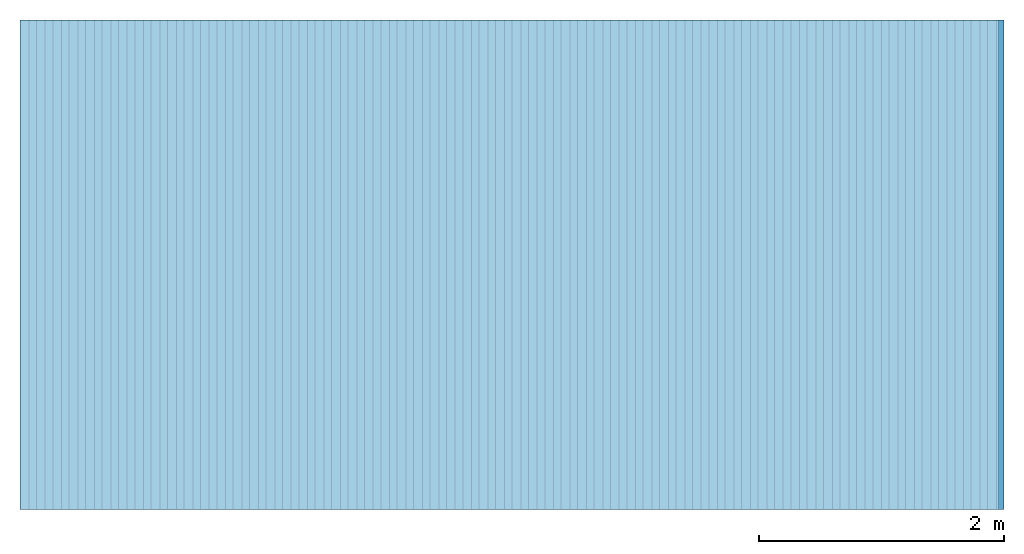
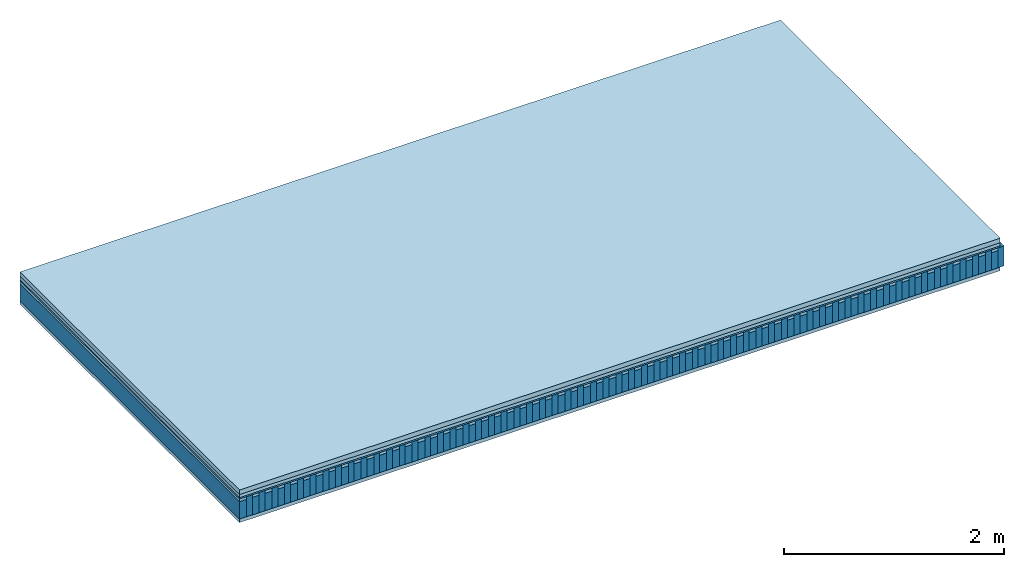
# One storey: 5 plates, 2 members, 1 element without a shape of its own.
"""IFC4 building model written with IfcOpenShell, lengths in metres."""

import ifcopenshell
import ifcopenshell.guid

model = None  # the IFC model being written
_history = None  # IfcOwnerHistory: only IFC2X3 demands one
_inside = {}  # id of a spatial element -> (the spatial element, [elements in it])
_under = {}  # id of a project, library or spatial element -> (it, [spatial elements below it])
_declared = {}  # id of a project -> (the project, [libraries it declares])
_typed = {}  # id of a type object -> (the type object, [elements of that type])
_made_of = {}  # id of a material, layer set ... -> (it, [elements and type objects made of it])


def new_model(schema):
    """Start an empty IFC model of exactly this schema.

    Asked for "IFC4X3", IfcOpenShell would pick the latest addendum, in which some entities
    have other attributes; the version numbers below select the first issue.
    IFC2X3 requires an IfcOwnerHistory on every rooted entity: one is made here for all.
    """
    global model, _history
    if schema == "IFC4X3":
        model = ifcopenshell.file(schema_version=(4, 3, 0, 0))
    else:
        model = ifcopenshell.file(schema=schema)
    _inside.clear()
    _under.clear()
    _declared.clear()
    _typed.clear()
    _made_of.clear()
    _history = None
    if model.schema == "IFC2X3":
        org = make("IfcOrganization", Name="unknown")
        user = make(
            "IfcPersonAndOrganization",
            ThePerson=make("IfcPerson", FamilyName="unknown"),
            TheOrganization=org,
        )
        app = make(
            "IfcApplication",
            ApplicationDeveloper=org,
            Version="unknown",
            ApplicationFullName="unknown",
            ApplicationIdentifier="unknown",
        )
        _history = make(
            "IfcOwnerHistory",
            OwningUser=user,
            OwningApplication=app,
            ChangeAction="ADDED",
            CreationDate=0,
        )
    return model


def make(cls, **values):
    """One entity of the class cls with the attributes given. An attribute that is None is left unset."""
    return model.create_entity(
        cls, **{name: value for name, value in values.items() if value is not None}
    )


def rooted(cls, **values):
    """An entity with a GlobalId (a new one), such as an element, a storey or a relation."""
    return make(cls, GlobalId=ifcopenshell.guid.new(), OwnerHistory=_history, **values)


def si_unit(unit_type, name, prefix=None):
    """IfcSIUnit, for example si_unit("LENGTHUNIT", "METRE", prefix="MILLI")."""
    return make("IfcSIUnit", UnitType=unit_type, Prefix=prefix, Name=name)


def derived_unit(unit_type, elements):
    """IfcDerivedUnit: a product of units, each with its exponent."""
    return make(
        "IfcDerivedUnit",
        Elements=[
            make("IfcDerivedUnitElement", Unit=unit, Exponent=power)
            for unit, power in elements
        ],
        UnitType=unit_type,
    )


def assignment(units):
    """IfcUnitAssignment: the units of a project."""
    return None if units is None else make("IfcUnitAssignment", Units=units)


def point(xyz):
    """IfcCartesianPoint."""
    return None if xyz is None else make("IfcCartesianPoint", Coordinates=xyz)


def direction(xyz):
    """IfcDirection."""
    return None if xyz is None else make("IfcDirection", DirectionRatios=xyz)


def frame(location, z_axis=None, x_axis=None):
    """IfcAxis2Placement3D, a coordinate frame: its origin and axes. An axis left out is left unset."""
    return make(
        "IfcAxis2Placement3D",
        Location=point(location),
        Axis=direction(z_axis),
        RefDirection=direction(x_axis),
    )


def frame_2d(location, x_axis=None):
    """IfcAxis2Placement2D, a coordinate frame in the plane: its origin and x axis."""
    return make(
        "IfcAxis2Placement2D", Location=point(location), RefDirection=direction(x_axis)
    )


def origin():
    """The frame at (0, 0, 0) with its axes left unset."""
    return frame((0.0, 0.0, 0.0))


def origin_with_axes():
    """The frame at (0, 0, 0) with the z axis (0, 0, 1) and the x axis (1, 0, 0) written out."""
    return frame((0.0, 0.0, 0.0), z_axis=(0.0, 0.0, 1.0), x_axis=(1.0, 0.0, 0.0))


def place(relative_to, where):
    """IfcLocalPlacement: puts the frame where relative to a parent placement (None: the world)."""
    return make(
        "IfcLocalPlacement", PlacementRelTo=relative_to, RelativePlacement=where
    )


def context(
    kind, dimensions, precision=None, world=None, true_north=None, identifier=None
):
    """IfcGeometricRepresentationContext, for example the 3D "Model" context."""
    return make(
        "IfcGeometricRepresentationContext",
        ContextIdentifier=identifier,
        ContextType=kind,
        CoordinateSpaceDimension=dimensions,
        Precision=precision,
        WorldCoordinateSystem=world,
        TrueNorth=true_north,
    )


def project(units=None, contexts=None):
    """IfcProject with its units and contexts."""
    return rooted(
        "IfcProject",
        Name="project",
        RepresentationContexts=contexts,
        UnitsInContext=assignment(units),
    )


def spatial(cls, under=None, at=None, **own):
    """A site, building, storey or space (cls), placed at a placement, below another one or the project."""
    s = rooted(cls, ObjectPlacement=at, **own)
    if under is not None:
        _under.setdefault(under.id(), (under, []))[1].append(s)
    return s


def profile(cls, at=None, kind="AREA", **sizes):
    """A parametric profile (cls). Its sizes go by their IFC names, for example OverallWidth=200.0."""
    return make(cls, ProfileType=kind, Position=at, **sizes)


def rectangle(**sizes):
    """IfcRectangleProfileDef."""
    return profile("IfcRectangleProfileDef", **sizes)


def extrude(swept, where, along, depth):
    """IfcExtrudedAreaSolid: the profile swept, set in the frame where, extruded along a direction by depth."""
    return make(
        "IfcExtrudedAreaSolid",
        SweptArea=swept,
        Position=where,
        ExtrudedDirection=direction(along),
        Depth=depth,
    )


def shape(context_of_items, identifier, shape_type, items):
    """IfcShapeRepresentation: the items that make up one representation, for example the "Body"."""
    return make(
        "IfcShapeRepresentation",
        ContextOfItems=context_of_items,
        RepresentationIdentifier=identifier,
        RepresentationType=shape_type,
        Items=items,
    )


def material(Name=None, Category=None):
    """IfcMaterial."""
    return make("IfcMaterial", Name=Name, Category=Category)


def layer(
    of_material, thickness, ventilated=None, Name=None, Category=None, Priority=None
):
    """IfcMaterialLayer: one layer of a wall or slab, of a material (None: an air gap)."""
    return make(
        "IfcMaterialLayer",
        Material=of_material,
        LayerThickness=thickness,
        IsVentilated=ventilated,
        Name=Name,
        Category=Category,
        Priority=Priority,
    )


def layer_set(layers, Name=None):
    """IfcMaterialLayerSet."""
    return make("IfcMaterialLayerSet", MaterialLayers=layers, LayerSetName=Name)


def made_of(thing, what):
    """Note that an element or type object is made of a material, layer set ...; save() writes the relation."""
    if what is not None:
        _made_of.setdefault(what.id(), (what, []))[1].append(thing)
    return thing


def type_object(cls, material=None, **own):
    """A type object (cls), such as IfcWallType, which elements share."""
    return made_of(rooted(cls, **own), material)


def element(
    cls,
    number,
    at=None,
    inside=None,
    cuts=None,
    type_object=None,
    material=None,
    context=None,
    identifier="Body",
    shape_type=None,
    held_by="IfcProductDefinitionShape",
    body=None,
    shapes=None,
    **own,
):
    """One element of the class cls, such as IfcWall. Its Tag is "e" and its number.

    at: its placement. inside: the storey or other place that contains it. cuts: it is an
    opening in that element (IfcRelVoidsElement). A single representation is given by context,
    identifier, shape_type and body (its items); several are given by shapes. held_by: the class
    of the entity that holds the representations. save() writes the other relations.
    """
    e = rooted(cls, Tag="e%d" % number, ObjectPlacement=at, **own)
    if body is not None:
        shapes = [shape(context, identifier, shape_type, body)]
    if shapes is not None:
        e.Representation = make(held_by, Representations=shapes)
    if inside is not None:
        _inside.setdefault(inside.id(), (inside, []))[1].append(e)
    if cuts is not None:
        rooted(
            "IfcRelVoidsElement", RelatingBuildingElement=cuts, RelatedOpeningElement=e
        )
    if type_object is not None:
        _typed.setdefault(type_object.id(), (type_object, []))[1].append(e)
    return made_of(e, material)


def aggregate(whole, parts):
    """IfcRelAggregates: a whole, such as a stair, and the parts it consists of."""
    return rooted("IfcRelAggregates", RelatingObject=whole, RelatedObjects=parts)


def save(model, path):
    """Write the relations noted so far, then the file.

    IfcRelAggregates (storeys below a building ...), IfcRelContainedInSpatialStructure (elements
    in a storey), IfcRelDefinesByType, IfcRelAssociatesMaterial and IfcRelDeclares: one each for
    every whole, place, type object, material and project.
    """
    for whole, parts in _under.values():
        aggregate(whole, parts)
    for where, things in _inside.values():
        rooted(
            "IfcRelContainedInSpatialStructure",
            RelatedElements=things,
            RelatingStructure=where,
        )
    for kind, things in _typed.values():
        rooted("IfcRelDefinesByType", RelatedObjects=things, RelatingType=kind)
    for what, things in _made_of.values():
        rooted("IfcRelAssociatesMaterial", RelatedObjects=things, RelatingMaterial=what)
    for by, libraries in _declared.values():
        rooted("IfcRelDeclares", RelatingContext=by, RelatedDefinitions=libraries)
    model.write(path)


model = new_model("IFC4")

# Units and contexts
plan_context = context("Plan", 3, precision=1e-05, world=origin(), true_north=direction((0.0, 1.0)))
model_context = context("Model", 3, precision=1e-05, world=origin(), true_north=direction((0.0, 1.0)))
ifc_project = project(units=[si_unit("LENGTHUNIT", "METRE"), derived_unit("SOUNDPRESSUREUNIT", [(si_unit("PRESSUREUNIT", "PASCAL", prefix="MICRO"), 0)]), si_unit("ENERGYUNIT", "JOULE", prefix="MEGA"), si_unit("MASSUNIT", "GRAM", prefix="KILO"), derived_unit("THERMALTRANSMITTANCEUNIT", [(si_unit("POWERUNIT", "WATT"), 1), (si_unit("AREAUNIT", "SQUARE_METRE"), -1), (si_unit("THERMODYNAMICTEMPERATUREUNIT", "KELVIN"), -1)]), derived_unit("AREADENSITYUNIT", [(si_unit("MASSUNIT", "GRAM", prefix="KILO"), 1), (si_unit("AREAUNIT", "SQUARE_METRE"), -1)]), derived_unit("USERDEFINED", [(si_unit("ENERGYUNIT", "JOULE", prefix="MEGA"), 1), (si_unit("AREAUNIT", "SQUARE_METRE"), -1)])], contexts=[plan_context, model_context])

# Site, building, storey
site = spatial("IfcSite", under=ifc_project)
building_placement = place(None, origin())
building = spatial("IfcBuilding", under=site, at=building_placement)
storey_placement = place(building_placement, origin())
storey = spatial("IfcBuildingStorey", under=building, at=storey_placement)

# Slab, members, plates
ifc_material_1 = material(Name="Cement screed", Category="04.006")
ifc_layer_1 = layer(ifc_material_1, 0.0505, Name="On-material")
ifc_material_2 = material(Name="EP1, 40/35mm")
ifc_layer_2 = layer(ifc_material_2, 0.035, Name="Impact sound insulation")
ifc_material_3 = material(Name="Standard-n", Category="10.009")
ifc_layer_3 = layer(ifc_material_3, 0.015, Name="Additional insulation")
ifc_material_4 = material()
ifc_layer_4 = layer(ifc_material_4, 0.03, Name="Sub-floor")
ifc_material_5 = material(Name="Rigid, of the art")
ifc_layer_5 = layer(ifc_material_5, 0.0, Name="Bond")
ifc_layer_6 = layer(None, 0.193, Name="Supporting structure")
ifc_layer_7 = layer(ifc_material_5, 0.0, Name="Bond")
ifc_material_6 = material(Name="panel on the underside HBF 40mm (20+20mm)", Category="07.001")
ifc_layer_8 = layer(ifc_material_6, 0.039, Name="Lower layer 1")
ifc_layer_set = layer_set([ifc_layer_1, ifc_layer_2, ifc_layer_3, ifc_layer_4, ifc_layer_5, ifc_layer_6, ifc_layer_7, ifc_layer_8])
slab_type = type_object("IfcSlabType", Name="A0044", PredefinedType="NOTDEFINED", material=ifc_layer_set)
slab_placement = place(None, frame((0.0, 0.0, 0.0), z_axis=(0.0, 0.0, -1.0), x_axis=(1.0, 0.0, 0.0)))
slab = element("IfcSlab", 1, at=slab_placement, inside=storey, type_object=slab_type, material=ifc_layer_set, Name="Slab #1")
ifc_material_7 = material(Name="Block Q3")
member_1_placement = place(slab_placement, origin())
member_1 = element("IfcMember", 2, at=member_1_placement, material=ifc_material_7, Name="Supporting structure", context=plan_context, shape_type="SweptSolid", body=[
    extrude(rectangle(XDim=0.071666666666667, YDim=0.193, at=frame_2d((0.0358333333333335, 0.0965), x_axis=(1.0, 0.0))), frame((0.0, 4.0, 0.1305), z_axis=(0.0, -1.0, 0.0), x_axis=(1.0, 0.0, 0.0)), (0.0, 0.0, 1.0), 4.0),
    extrude(rectangle(XDim=0.071666666666667, YDim=0.193, at=frame_2d((0.0358333333333335, 0.0965), x_axis=(1.0, 0.0))), frame((0.134, 4.0, 0.1305), z_axis=(0.0, -1.0, 0.0), x_axis=(1.0, 0.0, 0.0)), (0.0, 0.0, 1.0), 4.0),
    extrude(rectangle(XDim=0.071666666666667, YDim=0.193, at=frame_2d((0.0358333333333335, 0.0965), x_axis=(1.0, 0.0))), frame((0.268, 4.0, 0.1305), z_axis=(0.0, -1.0, 0.0), x_axis=(1.0, 0.0, 0.0)), (0.0, 0.0, 1.0), 4.0),
    extrude(rectangle(XDim=0.071666666666667, YDim=0.193, at=frame_2d((0.0358333333333335, 0.0965), x_axis=(1.0, 0.0))), frame((0.402, 4.0, 0.1305), z_axis=(0.0, -1.0, 0.0), x_axis=(1.0, 0.0, 0.0)), (0.0, 0.0, 1.0), 4.0),
    extrude(rectangle(XDim=0.071666666666667, YDim=0.193, at=frame_2d((0.0358333333333335, 0.0965), x_axis=(1.0, 0.0))), frame((0.536, 4.0, 0.1305), z_axis=(0.0, -1.0, 0.0), x_axis=(1.0, 0.0, 0.0)), (0.0, 0.0, 1.0), 4.0),
    extrude(rectangle(XDim=0.071666666666667, YDim=0.193, at=frame_2d((0.0358333333333335, 0.0965), x_axis=(1.0, 0.0))), frame((0.67, 4.0, 0.1305), z_axis=(0.0, -1.0, 0.0), x_axis=(1.0, 0.0, 0.0)), (0.0, 0.0, 1.0), 4.0),
    extrude(rectangle(XDim=0.071666666666667, YDim=0.193, at=frame_2d((0.0358333333333335, 0.0965), x_axis=(1.0, 0.0))), frame((0.804, 4.0, 0.1305), z_axis=(0.0, -1.0, 0.0), x_axis=(1.0, 0.0, 0.0)), (0.0, 0.0, 1.0), 4.0),
    extrude(rectangle(XDim=0.071666666666667, YDim=0.193, at=frame_2d((0.0358333333333335, 0.0965), x_axis=(1.0, 0.0))), frame((0.938, 4.0, 0.1305), z_axis=(0.0, -1.0, 0.0), x_axis=(1.0, 0.0, 0.0)), (0.0, 0.0, 1.0), 4.0),
    extrude(rectangle(XDim=0.071666666666667, YDim=0.193, at=frame_2d((0.0358333333333335, 0.0965), x_axis=(1.0, 0.0))), frame((1.072, 4.0, 0.1305), z_axis=(0.0, -1.0, 0.0), x_axis=(1.0, 0.0, 0.0)), (0.0, 0.0, 1.0), 4.0),
    extrude(rectangle(XDim=0.071666666666667, YDim=0.193, at=frame_2d((0.0358333333333335, 0.0965), x_axis=(1.0, 0.0))), frame((1.206, 4.0, 0.1305), z_axis=(0.0, -1.0, 0.0), x_axis=(1.0, 0.0, 0.0)), (0.0, 0.0, 1.0), 4.0),
    extrude(rectangle(XDim=0.071666666666667, YDim=0.193, at=frame_2d((0.0358333333333335, 0.0965), x_axis=(1.0, 0.0))), frame((1.34, 4.0, 0.1305), z_axis=(0.0, -1.0, 0.0), x_axis=(1.0, 0.0, 0.0)), (0.0, 0.0, 1.0), 4.0),
    extrude(rectangle(XDim=0.071666666666667, YDim=0.193, at=frame_2d((0.0358333333333335, 0.0965), x_axis=(1.0, 0.0))), frame((1.474, 4.0, 0.1305), z_axis=(0.0, -1.0, 0.0), x_axis=(1.0, 0.0, 0.0)), (0.0, 0.0, 1.0), 4.0),
    extrude(rectangle(XDim=0.071666666666667, YDim=0.193, at=frame_2d((0.0358333333333335, 0.0965), x_axis=(1.0, 0.0))), frame((1.608, 4.0, 0.1305), z_axis=(0.0, -1.0, 0.0), x_axis=(1.0, 0.0, 0.0)), (0.0, 0.0, 1.0), 4.0),
    extrude(rectangle(XDim=0.071666666666667, YDim=0.193, at=frame_2d((0.0358333333333335, 0.0965), x_axis=(1.0, 0.0))), frame((1.742, 4.0, 0.1305), z_axis=(0.0, -1.0, 0.0), x_axis=(1.0, 0.0, 0.0)), (0.0, 0.0, 1.0), 4.0),
    extrude(rectangle(XDim=0.071666666666667, YDim=0.193, at=frame_2d((0.0358333333333335, 0.0965), x_axis=(1.0, 0.0))), frame((1.876, 4.0, 0.1305), z_axis=(0.0, -1.0, 0.0), x_axis=(1.0, 0.0, 0.0)), (0.0, 0.0, 1.0), 4.0),
    extrude(rectangle(XDim=0.071666666666667, YDim=0.193, at=frame_2d((0.0358333333333335, 0.0965), x_axis=(1.0, 0.0))), frame((2.01, 4.0, 0.1305), z_axis=(0.0, -1.0, 0.0), x_axis=(1.0, 0.0, 0.0)), (0.0, 0.0, 1.0), 4.0),
    extrude(rectangle(XDim=0.071666666666667, YDim=0.193, at=frame_2d((0.0358333333333335, 0.0965), x_axis=(1.0, 0.0))), frame((2.144, 4.0, 0.1305), z_axis=(0.0, -1.0, 0.0), x_axis=(1.0, 0.0, 0.0)), (0.0, 0.0, 1.0), 4.0),
    extrude(rectangle(XDim=0.071666666666667, YDim=0.193, at=frame_2d((0.0358333333333335, 0.0965), x_axis=(1.0, 0.0))), frame((2.278, 4.0, 0.1305), z_axis=(0.0, -1.0, 0.0), x_axis=(1.0, 0.0, 0.0)), (0.0, 0.0, 1.0), 4.0),
    extrude(rectangle(XDim=0.071666666666667, YDim=0.193, at=frame_2d((0.0358333333333335, 0.0965), x_axis=(1.0, 0.0))), frame((2.412, 4.0, 0.1305), z_axis=(0.0, -1.0, 0.0), x_axis=(1.0, 0.0, 0.0)), (0.0, 0.0, 1.0), 4.0),
    extrude(rectangle(XDim=0.071666666666667, YDim=0.193, at=frame_2d((0.0358333333333335, 0.0965), x_axis=(1.0, 0.0))), frame((2.546, 4.0, 0.1305), z_axis=(0.0, -1.0, 0.0), x_axis=(1.0, 0.0, 0.0)), (0.0, 0.0, 1.0), 4.0),
    extrude(rectangle(XDim=0.071666666666667, YDim=0.193, at=frame_2d((0.0358333333333335, 0.0965), x_axis=(1.0, 0.0))), frame((2.68, 4.0, 0.1305), z_axis=(0.0, -1.0, 0.0), x_axis=(1.0, 0.0, 0.0)), (0.0, 0.0, 1.0), 4.0),
    extrude(rectangle(XDim=0.071666666666667, YDim=0.193, at=frame_2d((0.0358333333333335, 0.0965), x_axis=(1.0, 0.0))), frame((2.814, 4.0, 0.1305), z_axis=(0.0, -1.0, 0.0), x_axis=(1.0, 0.0, 0.0)), (0.0, 0.0, 1.0), 4.0),
    extrude(rectangle(XDim=0.071666666666667, YDim=0.193, at=frame_2d((0.0358333333333335, 0.0965), x_axis=(1.0, 0.0))), frame((2.948, 4.0, 0.1305), z_axis=(0.0, -1.0, 0.0), x_axis=(1.0, 0.0, 0.0)), (0.0, 0.0, 1.0), 4.0),
    extrude(rectangle(XDim=0.071666666666667, YDim=0.193, at=frame_2d((0.0358333333333335, 0.0965), x_axis=(1.0, 0.0))), frame((3.082, 4.0, 0.1305), z_axis=(0.0, -1.0, 0.0), x_axis=(1.0, 0.0, 0.0)), (0.0, 0.0, 1.0), 4.0),
    extrude(rectangle(XDim=0.071666666666667, YDim=0.193, at=frame_2d((0.0358333333333335, 0.0965), x_axis=(1.0, 0.0))), frame((3.216, 4.0, 0.1305), z_axis=(0.0, -1.0, 0.0), x_axis=(1.0, 0.0, 0.0)), (0.0, 0.0, 1.0), 4.0),
    extrude(rectangle(XDim=0.071666666666667, YDim=0.193, at=frame_2d((0.0358333333333335, 0.0965), x_axis=(1.0, 0.0))), frame((3.35, 4.0, 0.1305), z_axis=(0.0, -1.0, 0.0), x_axis=(1.0, 0.0, 0.0)), (0.0, 0.0, 1.0), 4.0),
    extrude(rectangle(XDim=0.071666666666667, YDim=0.193, at=frame_2d((0.0358333333333335, 0.0965), x_axis=(1.0, 0.0))), frame((3.484, 4.0, 0.1305), z_axis=(0.0, -1.0, 0.0), x_axis=(1.0, 0.0, 0.0)), (0.0, 0.0, 1.0), 4.0),
    extrude(rectangle(XDim=0.071666666666667, YDim=0.193, at=frame_2d((0.0358333333333335, 0.0965), x_axis=(1.0, 0.0))), frame((3.618, 4.0, 0.1305), z_axis=(0.0, -1.0, 0.0), x_axis=(1.0, 0.0, 0.0)), (0.0, 0.0, 1.0), 4.0),
    extrude(rectangle(XDim=0.071666666666667, YDim=0.193, at=frame_2d((0.0358333333333335, 0.0965), x_axis=(1.0, 0.0))), frame((3.752, 4.0, 0.1305), z_axis=(0.0, -1.0, 0.0), x_axis=(1.0, 0.0, 0.0)), (0.0, 0.0, 1.0), 4.0),
    extrude(rectangle(XDim=0.071666666666667, YDim=0.193, at=frame_2d((0.0358333333333335, 0.0965), x_axis=(1.0, 0.0))), frame((3.886, 4.0, 0.1305), z_axis=(0.0, -1.0, 0.0), x_axis=(1.0, 0.0, 0.0)), (0.0, 0.0, 1.0), 4.0),
    extrude(rectangle(XDim=0.071666666666667, YDim=0.193, at=frame_2d((0.0358333333333335, 0.0965), x_axis=(1.0, 0.0))), frame((4.02, 4.0, 0.1305), z_axis=(0.0, -1.0, 0.0), x_axis=(1.0, 0.0, 0.0)), (0.0, 0.0, 1.0), 4.0),
    extrude(rectangle(XDim=0.071666666666667, YDim=0.193, at=frame_2d((0.0358333333333335, 0.0965), x_axis=(1.0, 0.0))), frame((4.154, 4.0, 0.1305), z_axis=(0.0, -1.0, 0.0), x_axis=(1.0, 0.0, 0.0)), (0.0, 0.0, 1.0), 4.0),
    extrude(rectangle(XDim=0.071666666666667, YDim=0.193, at=frame_2d((0.0358333333333335, 0.0965), x_axis=(1.0, 0.0))), frame((4.288, 4.0, 0.1305), z_axis=(0.0, -1.0, 0.0), x_axis=(1.0, 0.0, 0.0)), (0.0, 0.0, 1.0), 4.0),
    extrude(rectangle(XDim=0.071666666666667, YDim=0.193, at=frame_2d((0.0358333333333335, 0.0965), x_axis=(1.0, 0.0))), frame((4.422, 4.0, 0.1305), z_axis=(0.0, -1.0, 0.0), x_axis=(1.0, 0.0, 0.0)), (0.0, 0.0, 1.0), 4.0),
    extrude(rectangle(XDim=0.071666666666667, YDim=0.193, at=frame_2d((0.0358333333333335, 0.0965), x_axis=(1.0, 0.0))), frame((4.556, 4.0, 0.1305), z_axis=(0.0, -1.0, 0.0), x_axis=(1.0, 0.0, 0.0)), (0.0, 0.0, 1.0), 4.0),
    extrude(rectangle(XDim=0.071666666666667, YDim=0.193, at=frame_2d((0.0358333333333335, 0.0965), x_axis=(1.0, 0.0))), frame((4.69, 4.0, 0.1305), z_axis=(0.0, -1.0, 0.0), x_axis=(1.0, 0.0, 0.0)), (0.0, 0.0, 1.0), 4.0),
    extrude(rectangle(XDim=0.071666666666667, YDim=0.193, at=frame_2d((0.0358333333333335, 0.0965), x_axis=(1.0, 0.0))), frame((4.824, 4.0, 0.1305), z_axis=(0.0, -1.0, 0.0), x_axis=(1.0, 0.0, 0.0)), (0.0, 0.0, 1.0), 4.0),
    extrude(rectangle(XDim=0.071666666666667, YDim=0.193, at=frame_2d((0.0358333333333335, 0.0965), x_axis=(1.0, 0.0))), frame((4.958, 4.0, 0.1305), z_axis=(0.0, -1.0, 0.0), x_axis=(1.0, 0.0, 0.0)), (0.0, 0.0, 1.0), 4.0),
    extrude(rectangle(XDim=0.071666666666667, YDim=0.193, at=frame_2d((0.0358333333333335, 0.0965), x_axis=(1.0, 0.0))), frame((5.092, 4.0, 0.1305), z_axis=(0.0, -1.0, 0.0), x_axis=(1.0, 0.0, 0.0)), (0.0, 0.0, 1.0), 4.0),
    extrude(rectangle(XDim=0.071666666666667, YDim=0.193, at=frame_2d((0.0358333333333335, 0.0965), x_axis=(1.0, 0.0))), frame((5.226, 4.0, 0.1305), z_axis=(0.0, -1.0, 0.0), x_axis=(1.0, 0.0, 0.0)), (0.0, 0.0, 1.0), 4.0),
    extrude(rectangle(XDim=0.071666666666667, YDim=0.193, at=frame_2d((0.0358333333333335, 0.0965), x_axis=(1.0, 0.0))), frame((5.36, 4.0, 0.1305), z_axis=(0.0, -1.0, 0.0), x_axis=(1.0, 0.0, 0.0)), (0.0, 0.0, 1.0), 4.0),
    extrude(rectangle(XDim=0.071666666666667, YDim=0.193, at=frame_2d((0.0358333333333335, 0.0965), x_axis=(1.0, 0.0))), frame((5.494, 4.0, 0.1305), z_axis=(0.0, -1.0, 0.0), x_axis=(1.0, 0.0, 0.0)), (0.0, 0.0, 1.0), 4.0),
    extrude(rectangle(XDim=0.071666666666667, YDim=0.193, at=frame_2d((0.0358333333333335, 0.0965), x_axis=(1.0, 0.0))), frame((5.628, 4.0, 0.1305), z_axis=(0.0, -1.0, 0.0), x_axis=(1.0, 0.0, 0.0)), (0.0, 0.0, 1.0), 4.0),
    extrude(rectangle(XDim=0.071666666666667, YDim=0.193, at=frame_2d((0.0358333333333335, 0.0965), x_axis=(1.0, 0.0))), frame((5.762, 4.0, 0.1305), z_axis=(0.0, -1.0, 0.0), x_axis=(1.0, 0.0, 0.0)), (0.0, 0.0, 1.0), 4.0),
    extrude(rectangle(XDim=0.071666666666667, YDim=0.193, at=frame_2d((0.0358333333333335, 0.0965), x_axis=(1.0, 0.0))), frame((5.896, 4.0, 0.1305), z_axis=(0.0, -1.0, 0.0), x_axis=(1.0, 0.0, 0.0)), (0.0, 0.0, 1.0), 4.0),
    extrude(rectangle(XDim=0.071666666666667, YDim=0.193, at=frame_2d((0.0358333333333335, 0.0965), x_axis=(1.0, 0.0))), frame((6.03, 4.0, 0.1305), z_axis=(0.0, -1.0, 0.0), x_axis=(1.0, 0.0, 0.0)), (0.0, 0.0, 1.0), 4.0),
    extrude(rectangle(XDim=0.071666666666667, YDim=0.193, at=frame_2d((0.0358333333333335, 0.0965), x_axis=(1.0, 0.0))), frame((6.164, 4.0, 0.1305), z_axis=(0.0, -1.0, 0.0), x_axis=(1.0, 0.0, 0.0)), (0.0, 0.0, 1.0), 4.0),
    extrude(rectangle(XDim=0.071666666666667, YDim=0.193, at=frame_2d((0.0358333333333335, 0.0965), x_axis=(1.0, 0.0))), frame((6.298, 4.0, 0.1305), z_axis=(0.0, -1.0, 0.0), x_axis=(1.0, 0.0, 0.0)), (0.0, 0.0, 1.0), 4.0),
    extrude(rectangle(XDim=0.071666666666667, YDim=0.193, at=frame_2d((0.0358333333333335, 0.0965), x_axis=(1.0, 0.0))), frame((6.432, 4.0, 0.1305), z_axis=(0.0, -1.0, 0.0), x_axis=(1.0, 0.0, 0.0)), (0.0, 0.0, 1.0), 4.0),
    extrude(rectangle(XDim=0.071666666666667, YDim=0.193, at=frame_2d((0.0358333333333335, 0.0965), x_axis=(1.0, 0.0))), frame((6.566, 4.0, 0.1305), z_axis=(0.0, -1.0, 0.0), x_axis=(1.0, 0.0, 0.0)), (0.0, 0.0, 1.0), 4.0),
    extrude(rectangle(XDim=0.071666666666667, YDim=0.193, at=frame_2d((0.0358333333333335, 0.0965), x_axis=(1.0, 0.0))), frame((6.7, 4.0, 0.1305), z_axis=(0.0, -1.0, 0.0), x_axis=(1.0, 0.0, 0.0)), (0.0, 0.0, 1.0), 4.0),
    extrude(rectangle(XDim=0.071666666666667, YDim=0.193, at=frame_2d((0.0358333333333335, 0.0965), x_axis=(1.0, 0.0))), frame((6.834, 4.0, 0.1305), z_axis=(0.0, -1.0, 0.0), x_axis=(1.0, 0.0, 0.0)), (0.0, 0.0, 1.0), 4.0),
    extrude(rectangle(XDim=0.071666666666667, YDim=0.193, at=frame_2d((0.0358333333333335, 0.0965), x_axis=(1.0, 0.0))), frame((6.96800000000001, 4.0, 0.1305), z_axis=(0.0, -1.0, 0.0), x_axis=(1.0, 0.0, 0.0)), (0.0, 0.0, 1.0), 4.0),
    extrude(rectangle(XDim=0.071666666666667, YDim=0.193, at=frame_2d((0.0358333333333335, 0.0965), x_axis=(1.0, 0.0))), frame((7.10200000000001, 4.0, 0.1305), z_axis=(0.0, -1.0, 0.0), x_axis=(1.0, 0.0, 0.0)), (0.0, 0.0, 1.0), 4.0),
    extrude(rectangle(XDim=0.071666666666667, YDim=0.193, at=frame_2d((0.0358333333333335, 0.0965), x_axis=(1.0, 0.0))), frame((7.23600000000001, 4.0, 0.1305), z_axis=(0.0, -1.0, 0.0), x_axis=(1.0, 0.0, 0.0)), (0.0, 0.0, 1.0), 4.0),
    extrude(rectangle(XDim=0.071666666666667, YDim=0.193, at=frame_2d((0.0358333333333335, 0.0965), x_axis=(1.0, 0.0))), frame((7.37000000000001, 4.0, 0.1305), z_axis=(0.0, -1.0, 0.0), x_axis=(1.0, 0.0, 0.0)), (0.0, 0.0, 1.0), 4.0),
    extrude(rectangle(XDim=0.071666666666667, YDim=0.193, at=frame_2d((0.0358333333333335, 0.0965), x_axis=(1.0, 0.0))), frame((7.50400000000001, 4.0, 0.1305), z_axis=(0.0, -1.0, 0.0), x_axis=(1.0, 0.0, 0.0)), (0.0, 0.0, 1.0), 4.0),
    extrude(rectangle(XDim=0.071666666666667, YDim=0.193, at=frame_2d((0.0358333333333335, 0.0965), x_axis=(1.0, 0.0))), frame((7.63800000000001, 4.0, 0.1305), z_axis=(0.0, -1.0, 0.0), x_axis=(1.0, 0.0, 0.0)), (0.0, 0.0, 1.0), 4.0),
    extrude(rectangle(XDim=0.071666666666667, YDim=0.193, at=frame_2d((0.0358333333333335, 0.0965), x_axis=(1.0, 0.0))), frame((7.77200000000001, 4.0, 0.1305), z_axis=(0.0, -1.0, 0.0), x_axis=(1.0, 0.0, 0.0)), (0.0, 0.0, 1.0), 4.0),
    extrude(rectangle(XDim=0.071666666666667, YDim=0.193, at=frame_2d((0.0358333333333335, 0.0965), x_axis=(1.0, 0.0))), frame((7.90600000000001, 4.0, 0.1305), z_axis=(0.0, -1.0, 0.0), x_axis=(1.0, 0.0, 0.0)), (0.0, 0.0, 1.0), 4.0),
])
ifc_material_8 = material(Name="Gravel of lime 3-6 mm")
member_2_placement = place(slab_placement, origin())
member_2 = element("IfcMember", 3, at=member_2_placement, material=ifc_material_8, Name="in supporting structure", context=plan_context, shape_type="SweptSolid", body=[
    extrude(rectangle(XDim=0.062333333333333, YDim=0.223, at=frame_2d((0.0311666666666665, 0.1115), x_axis=(1.0, 0.0))), frame((0.071666666666667, 4.0, 0.1005), z_axis=(0.0, -1.0, 0.0), x_axis=(1.0, 0.0, 0.0)), (0.0, 0.0, 1.0), 4.0),
    extrude(rectangle(XDim=0.062333333333333, YDim=0.223, at=frame_2d((0.0311666666666665, 0.1115), x_axis=(1.0, 0.0))), frame((0.205666666666667, 4.0, 0.1005), z_axis=(0.0, -1.0, 0.0), x_axis=(1.0, 0.0, 0.0)), (0.0, 0.0, 1.0), 4.0),
    extrude(rectangle(XDim=0.062333333333333, YDim=0.223, at=frame_2d((0.0311666666666665, 0.1115), x_axis=(1.0, 0.0))), frame((0.339666666666667, 4.0, 0.1005), z_axis=(0.0, -1.0, 0.0), x_axis=(1.0, 0.0, 0.0)), (0.0, 0.0, 1.0), 4.0),
    extrude(rectangle(XDim=0.062333333333333, YDim=0.223, at=frame_2d((0.0311666666666665, 0.1115), x_axis=(1.0, 0.0))), frame((0.473666666666667, 4.0, 0.1005), z_axis=(0.0, -1.0, 0.0), x_axis=(1.0, 0.0, 0.0)), (0.0, 0.0, 1.0), 4.0),
    extrude(rectangle(XDim=0.062333333333333, YDim=0.223, at=frame_2d((0.0311666666666665, 0.1115), x_axis=(1.0, 0.0))), frame((0.607666666666667, 4.0, 0.1005), z_axis=(0.0, -1.0, 0.0), x_axis=(1.0, 0.0, 0.0)), (0.0, 0.0, 1.0), 4.0),
    extrude(rectangle(XDim=0.062333333333333, YDim=0.223, at=frame_2d((0.0311666666666665, 0.1115), x_axis=(1.0, 0.0))), frame((0.741666666666667, 4.0, 0.1005), z_axis=(0.0, -1.0, 0.0), x_axis=(1.0, 0.0, 0.0)), (0.0, 0.0, 1.0), 4.0),
    extrude(rectangle(XDim=0.062333333333333, YDim=0.223, at=frame_2d((0.0311666666666665, 0.1115), x_axis=(1.0, 0.0))), frame((0.875666666666667, 4.0, 0.1005), z_axis=(0.0, -1.0, 0.0), x_axis=(1.0, 0.0, 0.0)), (0.0, 0.0, 1.0), 4.0),
    extrude(rectangle(XDim=0.062333333333333, YDim=0.223, at=frame_2d((0.0311666666666665, 0.1115), x_axis=(1.0, 0.0))), frame((1.00966666666667, 4.0, 0.1005), z_axis=(0.0, -1.0, 0.0), x_axis=(1.0, 0.0, 0.0)), (0.0, 0.0, 1.0), 4.0),
    extrude(rectangle(XDim=0.062333333333333, YDim=0.223, at=frame_2d((0.0311666666666665, 0.1115), x_axis=(1.0, 0.0))), frame((1.14366666666667, 4.0, 0.1005), z_axis=(0.0, -1.0, 0.0), x_axis=(1.0, 0.0, 0.0)), (0.0, 0.0, 1.0), 4.0),
    extrude(rectangle(XDim=0.062333333333333, YDim=0.223, at=frame_2d((0.0311666666666665, 0.1115), x_axis=(1.0, 0.0))), frame((1.27766666666667, 4.0, 0.1005), z_axis=(0.0, -1.0, 0.0), x_axis=(1.0, 0.0, 0.0)), (0.0, 0.0, 1.0), 4.0),
    extrude(rectangle(XDim=0.062333333333333, YDim=0.223, at=frame_2d((0.0311666666666665, 0.1115), x_axis=(1.0, 0.0))), frame((1.41166666666667, 4.0, 0.1005), z_axis=(0.0, -1.0, 0.0), x_axis=(1.0, 0.0, 0.0)), (0.0, 0.0, 1.0), 4.0),
    extrude(rectangle(XDim=0.062333333333333, YDim=0.223, at=frame_2d((0.0311666666666665, 0.1115), x_axis=(1.0, 0.0))), frame((1.54566666666667, 4.0, 0.1005), z_axis=(0.0, -1.0, 0.0), x_axis=(1.0, 0.0, 0.0)), (0.0, 0.0, 1.0), 4.0),
    extrude(rectangle(XDim=0.062333333333333, YDim=0.223, at=frame_2d((0.0311666666666665, 0.1115), x_axis=(1.0, 0.0))), frame((1.67966666666667, 4.0, 0.1005), z_axis=(0.0, -1.0, 0.0), x_axis=(1.0, 0.0, 0.0)), (0.0, 0.0, 1.0), 4.0),
    extrude(rectangle(XDim=0.062333333333333, YDim=0.223, at=frame_2d((0.0311666666666665, 0.1115), x_axis=(1.0, 0.0))), frame((1.81366666666667, 4.0, 0.1005), z_axis=(0.0, -1.0, 0.0), x_axis=(1.0, 0.0, 0.0)), (0.0, 0.0, 1.0), 4.0),
    extrude(rectangle(XDim=0.062333333333333, YDim=0.223, at=frame_2d((0.0311666666666665, 0.1115), x_axis=(1.0, 0.0))), frame((1.94766666666667, 4.0, 0.1005), z_axis=(0.0, -1.0, 0.0), x_axis=(1.0, 0.0, 0.0)), (0.0, 0.0, 1.0), 4.0),
    extrude(rectangle(XDim=0.062333333333333, YDim=0.223, at=frame_2d((0.0311666666666665, 0.1115), x_axis=(1.0, 0.0))), frame((2.08166666666667, 4.0, 0.1005), z_axis=(0.0, -1.0, 0.0), x_axis=(1.0, 0.0, 0.0)), (0.0, 0.0, 1.0), 4.0),
    extrude(rectangle(XDim=0.062333333333333, YDim=0.223, at=frame_2d((0.0311666666666665, 0.1115), x_axis=(1.0, 0.0))), frame((2.21566666666667, 4.0, 0.1005), z_axis=(0.0, -1.0, 0.0), x_axis=(1.0, 0.0, 0.0)), (0.0, 0.0, 1.0), 4.0),
    extrude(rectangle(XDim=0.062333333333333, YDim=0.223, at=frame_2d((0.0311666666666665, 0.1115), x_axis=(1.0, 0.0))), frame((2.34966666666667, 4.0, 0.1005), z_axis=(0.0, -1.0, 0.0), x_axis=(1.0, 0.0, 0.0)), (0.0, 0.0, 1.0), 4.0),
    extrude(rectangle(XDim=0.062333333333333, YDim=0.223, at=frame_2d((0.0311666666666665, 0.1115), x_axis=(1.0, 0.0))), frame((2.48366666666667, 4.0, 0.1005), z_axis=(0.0, -1.0, 0.0), x_axis=(1.0, 0.0, 0.0)), (0.0, 0.0, 1.0), 4.0),
    extrude(rectangle(XDim=0.062333333333333, YDim=0.223, at=frame_2d((0.0311666666666665, 0.1115), x_axis=(1.0, 0.0))), frame((2.61766666666667, 4.0, 0.1005), z_axis=(0.0, -1.0, 0.0), x_axis=(1.0, 0.0, 0.0)), (0.0, 0.0, 1.0), 4.0),
    extrude(rectangle(XDim=0.062333333333333, YDim=0.223, at=frame_2d((0.0311666666666665, 0.1115), x_axis=(1.0, 0.0))), frame((2.75166666666667, 4.0, 0.1005), z_axis=(0.0, -1.0, 0.0), x_axis=(1.0, 0.0, 0.0)), (0.0, 0.0, 1.0), 4.0),
    extrude(rectangle(XDim=0.062333333333333, YDim=0.223, at=frame_2d((0.0311666666666665, 0.1115), x_axis=(1.0, 0.0))), frame((2.88566666666667, 4.0, 0.1005), z_axis=(0.0, -1.0, 0.0), x_axis=(1.0, 0.0, 0.0)), (0.0, 0.0, 1.0), 4.0),
    extrude(rectangle(XDim=0.062333333333333, YDim=0.223, at=frame_2d((0.0311666666666665, 0.1115), x_axis=(1.0, 0.0))), frame((3.01966666666667, 4.0, 0.1005), z_axis=(0.0, -1.0, 0.0), x_axis=(1.0, 0.0, 0.0)), (0.0, 0.0, 1.0), 4.0),
    extrude(rectangle(XDim=0.062333333333333, YDim=0.223, at=frame_2d((0.0311666666666665, 0.1115), x_axis=(1.0, 0.0))), frame((3.15366666666667, 4.0, 0.1005), z_axis=(0.0, -1.0, 0.0), x_axis=(1.0, 0.0, 0.0)), (0.0, 0.0, 1.0), 4.0),
    extrude(rectangle(XDim=0.062333333333333, YDim=0.223, at=frame_2d((0.0311666666666665, 0.1115), x_axis=(1.0, 0.0))), frame((3.28766666666667, 4.0, 0.1005), z_axis=(0.0, -1.0, 0.0), x_axis=(1.0, 0.0, 0.0)), (0.0, 0.0, 1.0), 4.0),
    extrude(rectangle(XDim=0.062333333333333, YDim=0.223, at=frame_2d((0.0311666666666665, 0.1115), x_axis=(1.0, 0.0))), frame((3.42166666666667, 4.0, 0.1005), z_axis=(0.0, -1.0, 0.0), x_axis=(1.0, 0.0, 0.0)), (0.0, 0.0, 1.0), 4.0),
    extrude(rectangle(XDim=0.062333333333333, YDim=0.223, at=frame_2d((0.0311666666666665, 0.1115), x_axis=(1.0, 0.0))), frame((3.55566666666666, 4.0, 0.1005), z_axis=(0.0, -1.0, 0.0), x_axis=(1.0, 0.0, 0.0)), (0.0, 0.0, 1.0), 4.0),
    extrude(rectangle(XDim=0.062333333333333, YDim=0.223, at=frame_2d((0.0311666666666665, 0.1115), x_axis=(1.0, 0.0))), frame((3.68966666666666, 4.0, 0.1005), z_axis=(0.0, -1.0, 0.0), x_axis=(1.0, 0.0, 0.0)), (0.0, 0.0, 1.0), 4.0),
    extrude(rectangle(XDim=0.062333333333333, YDim=0.223, at=frame_2d((0.0311666666666665, 0.1115), x_axis=(1.0, 0.0))), frame((3.82366666666666, 4.0, 0.1005), z_axis=(0.0, -1.0, 0.0), x_axis=(1.0, 0.0, 0.0)), (0.0, 0.0, 1.0), 4.0),
    extrude(rectangle(XDim=0.062333333333333, YDim=0.223, at=frame_2d((0.0311666666666665, 0.1115), x_axis=(1.0, 0.0))), frame((3.95766666666666, 4.0, 0.1005), z_axis=(0.0, -1.0, 0.0), x_axis=(1.0, 0.0, 0.0)), (0.0, 0.0, 1.0), 4.0),
    extrude(rectangle(XDim=0.062333333333333, YDim=0.223, at=frame_2d((0.0311666666666665, 0.1115), x_axis=(1.0, 0.0))), frame((4.09166666666667, 4.0, 0.1005), z_axis=(0.0, -1.0, 0.0), x_axis=(1.0, 0.0, 0.0)), (0.0, 0.0, 1.0), 4.0),
    extrude(rectangle(XDim=0.062333333333333, YDim=0.223, at=frame_2d((0.0311666666666665, 0.1115), x_axis=(1.0, 0.0))), frame((4.22566666666667, 4.0, 0.1005), z_axis=(0.0, -1.0, 0.0), x_axis=(1.0, 0.0, 0.0)), (0.0, 0.0, 1.0), 4.0),
    extrude(rectangle(XDim=0.062333333333333, YDim=0.223, at=frame_2d((0.0311666666666665, 0.1115), x_axis=(1.0, 0.0))), frame((4.35966666666667, 4.0, 0.1005), z_axis=(0.0, -1.0, 0.0), x_axis=(1.0, 0.0, 0.0)), (0.0, 0.0, 1.0), 4.0),
    extrude(rectangle(XDim=0.062333333333333, YDim=0.223, at=frame_2d((0.0311666666666665, 0.1115), x_axis=(1.0, 0.0))), frame((4.49366666666667, 4.0, 0.1005), z_axis=(0.0, -1.0, 0.0), x_axis=(1.0, 0.0, 0.0)), (0.0, 0.0, 1.0), 4.0),
    extrude(rectangle(XDim=0.062333333333333, YDim=0.223, at=frame_2d((0.0311666666666665, 0.1115), x_axis=(1.0, 0.0))), frame((4.62766666666667, 4.0, 0.1005), z_axis=(0.0, -1.0, 0.0), x_axis=(1.0, 0.0, 0.0)), (0.0, 0.0, 1.0), 4.0),
    extrude(rectangle(XDim=0.062333333333333, YDim=0.223, at=frame_2d((0.0311666666666665, 0.1115), x_axis=(1.0, 0.0))), frame((4.76166666666667, 4.0, 0.1005), z_axis=(0.0, -1.0, 0.0), x_axis=(1.0, 0.0, 0.0)), (0.0, 0.0, 1.0), 4.0),
    extrude(rectangle(XDim=0.062333333333333, YDim=0.223, at=frame_2d((0.0311666666666665, 0.1115), x_axis=(1.0, 0.0))), frame((4.89566666666667, 4.0, 0.1005), z_axis=(0.0, -1.0, 0.0), x_axis=(1.0, 0.0, 0.0)), (0.0, 0.0, 1.0), 4.0),
    extrude(rectangle(XDim=0.062333333333333, YDim=0.223, at=frame_2d((0.0311666666666665, 0.1115), x_axis=(1.0, 0.0))), frame((5.02966666666667, 4.0, 0.1005), z_axis=(0.0, -1.0, 0.0), x_axis=(1.0, 0.0, 0.0)), (0.0, 0.0, 1.0), 4.0),
    extrude(rectangle(XDim=0.062333333333333, YDim=0.223, at=frame_2d((0.0311666666666665, 0.1115), x_axis=(1.0, 0.0))), frame((5.16366666666667, 4.0, 0.1005), z_axis=(0.0, -1.0, 0.0), x_axis=(1.0, 0.0, 0.0)), (0.0, 0.0, 1.0), 4.0),
    extrude(rectangle(XDim=0.062333333333333, YDim=0.223, at=frame_2d((0.0311666666666665, 0.1115), x_axis=(1.0, 0.0))), frame((5.29766666666667, 4.0, 0.1005), z_axis=(0.0, -1.0, 0.0), x_axis=(1.0, 0.0, 0.0)), (0.0, 0.0, 1.0), 4.0),
    extrude(rectangle(XDim=0.062333333333333, YDim=0.223, at=frame_2d((0.0311666666666665, 0.1115), x_axis=(1.0, 0.0))), frame((5.43166666666667, 4.0, 0.1005), z_axis=(0.0, -1.0, 0.0), x_axis=(1.0, 0.0, 0.0)), (0.0, 0.0, 1.0), 4.0),
    extrude(rectangle(XDim=0.062333333333333, YDim=0.223, at=frame_2d((0.0311666666666665, 0.1115), x_axis=(1.0, 0.0))), frame((5.56566666666667, 4.0, 0.1005), z_axis=(0.0, -1.0, 0.0), x_axis=(1.0, 0.0, 0.0)), (0.0, 0.0, 1.0), 4.0),
    extrude(rectangle(XDim=0.062333333333333, YDim=0.223, at=frame_2d((0.0311666666666665, 0.1115), x_axis=(1.0, 0.0))), frame((5.69966666666667, 4.0, 0.1005), z_axis=(0.0, -1.0, 0.0), x_axis=(1.0, 0.0, 0.0)), (0.0, 0.0, 1.0), 4.0),
    extrude(rectangle(XDim=0.062333333333333, YDim=0.223, at=frame_2d((0.0311666666666665, 0.1115), x_axis=(1.0, 0.0))), frame((5.83366666666667, 4.0, 0.1005), z_axis=(0.0, -1.0, 0.0), x_axis=(1.0, 0.0, 0.0)), (0.0, 0.0, 1.0), 4.0),
    extrude(rectangle(XDim=0.062333333333333, YDim=0.223, at=frame_2d((0.0311666666666665, 0.1115), x_axis=(1.0, 0.0))), frame((5.96766666666667, 4.0, 0.1005), z_axis=(0.0, -1.0, 0.0), x_axis=(1.0, 0.0, 0.0)), (0.0, 0.0, 1.0), 4.0),
    extrude(rectangle(XDim=0.062333333333333, YDim=0.223, at=frame_2d((0.0311666666666665, 0.1115), x_axis=(1.0, 0.0))), frame((6.10166666666667, 4.0, 0.1005), z_axis=(0.0, -1.0, 0.0), x_axis=(1.0, 0.0, 0.0)), (0.0, 0.0, 1.0), 4.0),
    extrude(rectangle(XDim=0.062333333333333, YDim=0.223, at=frame_2d((0.0311666666666665, 0.1115), x_axis=(1.0, 0.0))), frame((6.23566666666667, 4.0, 0.1005), z_axis=(0.0, -1.0, 0.0), x_axis=(1.0, 0.0, 0.0)), (0.0, 0.0, 1.0), 4.0),
    extrude(rectangle(XDim=0.062333333333333, YDim=0.223, at=frame_2d((0.0311666666666665, 0.1115), x_axis=(1.0, 0.0))), frame((6.36966666666667, 4.0, 0.1005), z_axis=(0.0, -1.0, 0.0), x_axis=(1.0, 0.0, 0.0)), (0.0, 0.0, 1.0), 4.0),
    extrude(rectangle(XDim=0.062333333333333, YDim=0.223, at=frame_2d((0.0311666666666665, 0.1115), x_axis=(1.0, 0.0))), frame((6.50366666666667, 4.0, 0.1005), z_axis=(0.0, -1.0, 0.0), x_axis=(1.0, 0.0, 0.0)), (0.0, 0.0, 1.0), 4.0),
    extrude(rectangle(XDim=0.062333333333333, YDim=0.223, at=frame_2d((0.0311666666666665, 0.1115), x_axis=(1.0, 0.0))), frame((6.63766666666667, 4.0, 0.1005), z_axis=(0.0, -1.0, 0.0), x_axis=(1.0, 0.0, 0.0)), (0.0, 0.0, 1.0), 4.0),
    extrude(rectangle(XDim=0.062333333333333, YDim=0.223, at=frame_2d((0.0311666666666665, 0.1115), x_axis=(1.0, 0.0))), frame((6.77166666666667, 4.0, 0.1005), z_axis=(0.0, -1.0, 0.0), x_axis=(1.0, 0.0, 0.0)), (0.0, 0.0, 1.0), 4.0),
    extrude(rectangle(XDim=0.062333333333333, YDim=0.223, at=frame_2d((0.0311666666666665, 0.1115), x_axis=(1.0, 0.0))), frame((6.90566666666667, 4.0, 0.1005), z_axis=(0.0, -1.0, 0.0), x_axis=(1.0, 0.0, 0.0)), (0.0, 0.0, 1.0), 4.0),
    extrude(rectangle(XDim=0.062333333333333, YDim=0.223, at=frame_2d((0.0311666666666665, 0.1115), x_axis=(1.0, 0.0))), frame((7.03966666666667, 4.0, 0.1005), z_axis=(0.0, -1.0, 0.0), x_axis=(1.0, 0.0, 0.0)), (0.0, 0.0, 1.0), 4.0),
    extrude(rectangle(XDim=0.062333333333333, YDim=0.223, at=frame_2d((0.0311666666666665, 0.1115), x_axis=(1.0, 0.0))), frame((7.17366666666667, 4.0, 0.1005), z_axis=(0.0, -1.0, 0.0), x_axis=(1.0, 0.0, 0.0)), (0.0, 0.0, 1.0), 4.0),
    extrude(rectangle(XDim=0.062333333333333, YDim=0.223, at=frame_2d((0.0311666666666665, 0.1115), x_axis=(1.0, 0.0))), frame((7.30766666666667, 4.0, 0.1005), z_axis=(0.0, -1.0, 0.0), x_axis=(1.0, 0.0, 0.0)), (0.0, 0.0, 1.0), 4.0),
    extrude(rectangle(XDim=0.062333333333333, YDim=0.223, at=frame_2d((0.0311666666666665, 0.1115), x_axis=(1.0, 0.0))), frame((7.44166666666667, 4.0, 0.1005), z_axis=(0.0, -1.0, 0.0), x_axis=(1.0, 0.0, 0.0)), (0.0, 0.0, 1.0), 4.0),
    extrude(rectangle(XDim=0.062333333333333, YDim=0.223, at=frame_2d((0.0311666666666665, 0.1115), x_axis=(1.0, 0.0))), frame((7.57566666666667, 4.0, 0.1005), z_axis=(0.0, -1.0, 0.0), x_axis=(1.0, 0.0, 0.0)), (0.0, 0.0, 1.0), 4.0),
    extrude(rectangle(XDim=0.062333333333333, YDim=0.223, at=frame_2d((0.0311666666666665, 0.1115), x_axis=(1.0, 0.0))), frame((7.70966666666667, 4.0, 0.1005), z_axis=(0.0, -1.0, 0.0), x_axis=(1.0, 0.0, 0.0)), (0.0, 0.0, 1.0), 4.0),
    extrude(rectangle(XDim=0.062333333333333, YDim=0.223, at=frame_2d((0.0311666666666665, 0.1115), x_axis=(1.0, 0.0))), frame((7.84366666666667, 4.0, 0.1005), z_axis=(0.0, -1.0, 0.0), x_axis=(1.0, 0.0, 0.0)), (0.0, 0.0, 1.0), 4.0),
    extrude(rectangle(XDim=0.062333333333333, YDim=0.223, at=frame_2d((0.0311666666666665, 0.1115), x_axis=(1.0, 0.0))), frame((7.97766666666667, 4.0, 0.1005), z_axis=(0.0, -1.0, 0.0), x_axis=(1.0, 0.0, 0.0)), (0.0, 0.0, 1.0), 4.0),
])
plate_1_placement = place(slab_placement, origin())
plate_1 = element("IfcPlate", 4, at=plate_1_placement, material=ifc_material_1, Name="On-material", context=plan_context, shape_type="SweptSolid", body=[
    extrude(rectangle(XDim=8.0, YDim=4.0, at=frame_2d((4.0, 2.0), x_axis=(1.0, 0.0))), origin_with_axes(), (0.0, 0.0, 1.0), 0.0505),
])
plate_2_placement = place(slab_placement, origin())
plate_2 = element("IfcPlate", 5, at=plate_2_placement, material=ifc_material_2, Name="Impact sound insulation", context=plan_context, shape_type="SweptSolid", body=[
    extrude(rectangle(XDim=8.0, YDim=4.0, at=frame_2d((4.0, 2.0), x_axis=(1.0, 0.0))), frame((0.0, 0.0, 0.0505), z_axis=(0.0, 0.0, 1.0), x_axis=(1.0, 0.0, 0.0)), (0.0, 0.0, 1.0), 0.035),
])
plate_3_placement = place(slab_placement, origin())
plate_3 = element("IfcPlate", 6, at=plate_3_placement, material=ifc_material_3, Name="Additional insulation", context=plan_context, shape_type="SweptSolid", body=[
    extrude(rectangle(XDim=8.0, YDim=4.0, at=frame_2d((4.0, 2.0), x_axis=(1.0, 0.0))), frame((0.0, 0.0, 0.0855), z_axis=(0.0, 0.0, 1.0), x_axis=(1.0, 0.0, 0.0)), (0.0, 0.0, 1.0), 0.015),
])
plate_4_placement = place(slab_placement, origin())
plate_4 = element("IfcPlate", 7, at=plate_4_placement, material=ifc_material_4, Name="Sub-floor", context=plan_context, shape_type="SweptSolid", body=[
    extrude(rectangle(XDim=8.0, YDim=4.0, at=frame_2d((4.0, 2.0), x_axis=(1.0, 0.0))), frame((0.0, 0.0, 0.1005), z_axis=(0.0, 0.0, 1.0), x_axis=(1.0, 0.0, 0.0)), (0.0, 0.0, 1.0), 0.03),
])
plate_5_placement = place(slab_placement, origin())
plate_5 = element("IfcPlate", 8, at=plate_5_placement, material=ifc_material_6, Name="Lower layer 1", context=plan_context, shape_type="SweptSolid", body=[
    extrude(rectangle(XDim=8.0, YDim=4.0, at=frame_2d((4.0, 2.0), x_axis=(1.0, 0.0))), frame((0.0, 0.0, 0.3235), z_axis=(0.0, 0.0, 1.0), x_axis=(1.0, 0.0, 0.0)), (0.0, 0.0, 1.0), 0.039),
])
aggregate(slab, [plate_1, plate_2, plate_3, plate_4, member_1, member_2, plate_5])

save(model, "model.ifc")
